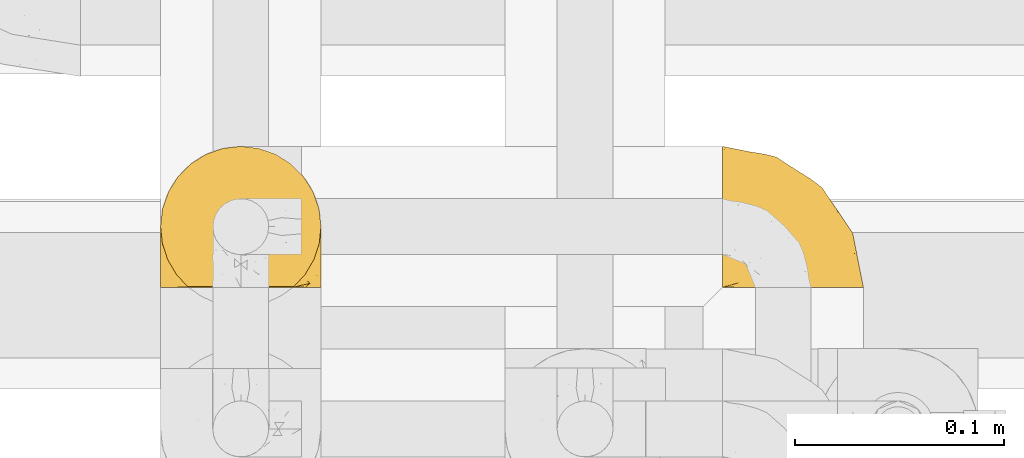
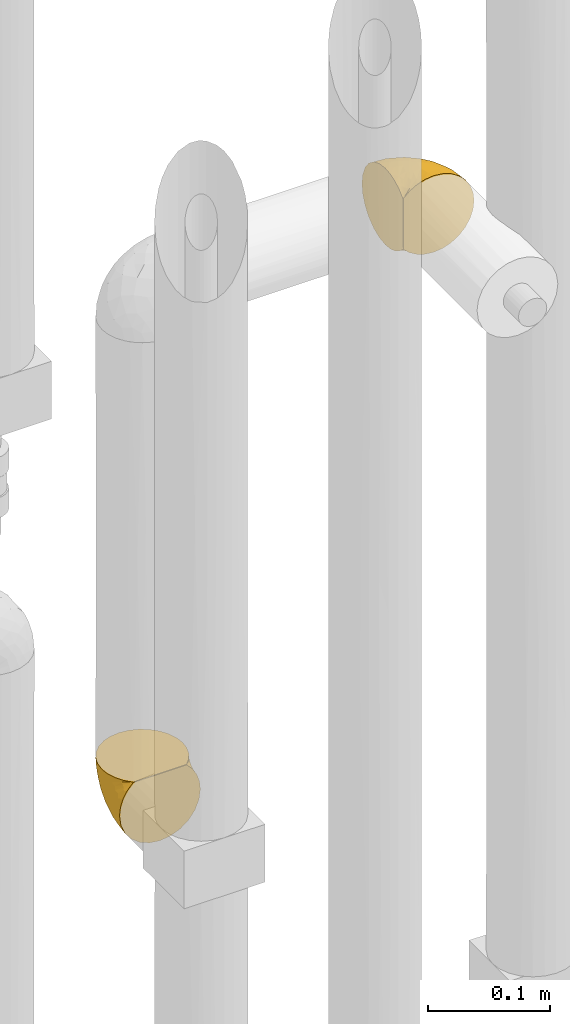
# One storey, part 284 of 827: 2 coverings.
"""IFC2X3 building model written with IfcOpenShell, lengths in millimetres."""

from ifc_helpers import new_model, entity, si_unit, converted_unit, derived_unit, direction, frame, origin, place, context, subcontext, project, spatial, faceted_brep, element, save


model = new_model("IFC2X3")

# Units and contexts
model_context = context("Model", 3, precision=0.01, world=origin(), true_north=direction((6.12303176911189e-17, 1.0)))
body_context = subcontext(model_context, "Body", "Model", "MODEL_VIEW")
ifc_project = project(units=[si_unit("LENGTHUNIT", "METRE", prefix="MILLI"), si_unit("AREAUNIT", "SQUARE_METRE"), si_unit("VOLUMEUNIT", "CUBIC_METRE"), converted_unit("PLANEANGLEUNIT", "DEGREE", entity("IfcRatioMeasure", 0.0174532925199433), si_unit("PLANEANGLEUNIT", "RADIAN"), dimensions=[0, 0, 0, 0, 0, 0, 0]), si_unit("MASSUNIT", "GRAM", prefix="KILO"), derived_unit("MASSDENSITYUNIT", [(si_unit("MASSUNIT", "GRAM", prefix="KILO"), 1), (si_unit("LENGTHUNIT", "METRE"), -3)]), derived_unit("MOMENTOFINERTIAUNIT", [(si_unit("LENGTHUNIT", "METRE"), 4)]), si_unit("TIMEUNIT", "SECOND"), si_unit("FREQUENCYUNIT", "HERTZ"), si_unit("THERMODYNAMICTEMPERATUREUNIT", "DEGREE_CELSIUS"), derived_unit("THERMALTRANSMITTANCEUNIT", [(si_unit("MASSUNIT", "GRAM", prefix="KILO"), 1), (si_unit("THERMODYNAMICTEMPERATUREUNIT", "KELVIN"), -1), (si_unit("TIMEUNIT", "SECOND"), -3)]), derived_unit("VOLUMETRICFLOWRATEUNIT", [(si_unit("LENGTHUNIT", "METRE"), 3), (si_unit("TIMEUNIT", "SECOND"), -1)]), derived_unit("MASSFLOWRATEUNIT", [(si_unit("MASSUNIT", "GRAM", prefix="KILO"), 1), (si_unit("TIMEUNIT", "SECOND"), -1)]), derived_unit("ROTATIONALFREQUENCYUNIT", [(si_unit("TIMEUNIT", "SECOND"), -1)]), si_unit("ELECTRICCURRENTUNIT", "AMPERE"), si_unit("ELECTRICVOLTAGEUNIT", "VOLT"), si_unit("POWERUNIT", "WATT"), si_unit("FORCEUNIT", "NEWTON", prefix="KILO"), si_unit("ILLUMINANCEUNIT", "LUX"), si_unit("LUMINOUSFLUXUNIT", "LUMEN"), si_unit("LUMINOUSINTENSITYUNIT", "CANDELA"), derived_unit("USERDEFINED", [(si_unit("MASSUNIT", "GRAM", prefix="KILO"), -1), (si_unit("LENGTHUNIT", "METRE"), -2), (si_unit("TIMEUNIT", "SECOND"), 3), (si_unit("LUMINOUSFLUXUNIT", "LUMEN"), 1)]), derived_unit("LINEARVELOCITYUNIT", [(si_unit("LENGTHUNIT", "METRE"), 1), (si_unit("TIMEUNIT", "SECOND"), -1)]), si_unit("PRESSUREUNIT", "PASCAL"), derived_unit("USERDEFINED", [(si_unit("LENGTHUNIT", "METRE"), -2), (si_unit("MASSUNIT", "GRAM", prefix="KILO"), 1), (si_unit("TIMEUNIT", "SECOND"), -2)]), derived_unit("LINEARFORCEUNIT", [(si_unit("MASSUNIT", "GRAM", prefix="KILO"), 1), (si_unit("LENGTHUNIT", "METRE"), 1), (si_unit("TIMEUNIT", "SECOND"), -2), (si_unit("LENGTHUNIT", "METRE"), -1)]), derived_unit("PLANARFORCEUNIT", [(si_unit("MASSUNIT", "GRAM", prefix="KILO"), 1), (si_unit("LENGTHUNIT", "METRE"), 1), (si_unit("TIMEUNIT", "SECOND"), -2), (si_unit("LENGTHUNIT", "METRE"), -2)])], contexts=[model_context])

# Site, building, storey
site_placement = place(None, origin())
site = spatial("IfcSite", under=ifc_project, at=site_placement, CompositionType="ELEMENT")
building_placement = place(site_placement, origin())
building = spatial("IfcBuilding", under=site, at=building_placement, CompositionType="ELEMENT")
storey_placement = place(building_placement, frame((0.0, 0.0, 28200.0)))
storey = spatial("IfcBuildingStorey", under=building, at=storey_placement, Name="08", CompositionType="ELEMENT", Elevation=28200.0)

# Coverings
covering_1_placement = place(storey_placement, frame((34787.8, 14991.21, 1669.95)))
element("IfcCovering", 1, at=covering_1_placement, inside=storey, Name=":ADSK_", ObjectType=":ADSK_", PredefinedType="INSULATION", context=body_context, shape_type="Brep", body=[
    faceted_brep([(74.68, 47.38, 69.15), (70.1, 54.67, 69.15), (64.01, 60.76, 69.15), (56.72, 65.34, 69.15), (48.6, 68.18, 69.15), (40.05, 69.15, 69.15), (31.49, 68.18, 69.15), (23.36, 65.33, 69.15), (16.07, 60.75, 69.15), (9.98, 54.66, 69.15), (5.4, 47.37, 69.15), (2.56, 39.25, 69.15), (1.6, 30.7, 69.15), (2.46, 22.59, 69.15), (5.01, 14.86, 69.15), (9.13, 7.84, 69.15), (14.62, 1.85, 69.15), (16.82, 1.85, 69.15), (18.56, 1.85, 69.15), (20.52, 1.85, 69.15), (22.49, 1.85, 69.15), (24.46, 1.85, 69.15), (26.42, 1.85, 69.15), (28.39, 1.85, 69.15), (30.36, 1.85, 69.15), (32.55, 1.85, 69.15), (34.75, 1.85, 69.15), (36.94, 1.85, 69.15), (39.13, 1.85, 69.15), (41.33, 1.85, 69.15), (43.52, 1.85, 69.15), (45.72, 1.85, 69.15), (47.91, 1.85, 69.15), (50.11, 1.85, 69.15), (52.3, 1.85, 69.15), (54.49, 1.85, 69.15), (56.69, 1.85, 69.15), (58.88, 1.85, 69.15), (61.08, 1.85, 69.15), (63.27, 1.85, 69.15), (65.47, 1.85, 69.15), (70.97, 7.85, 69.15), (75.09, 14.88, 69.15), (77.64, 22.61, 69.15), (78.5, 30.7, 69.15), (77.53, 39.26, 69.15), (14.62, 1.6, 68.89), (9.12, 1.6, 62.89), (5.0, 1.6, 55.87), (2.46, 1.6, 48.14), (1.6, 1.6, 40.05), (2.91, 1.6, 30.09), (6.75, 1.6, 20.82), (12.86, 1.6, 12.86), (20.82, 1.6, 6.75), (30.09, 1.6, 2.91), (40.05, 1.6, 1.6), (50.0, 1.6, 2.91), (59.27, 1.6, 6.75), (67.23, 1.6, 12.86), (73.34, 1.6, 20.82), (77.19, 1.6, 30.09), (78.5, 1.6, 40.05), (77.63, 1.6, 48.14), (75.09, 1.6, 55.87), (70.97, 1.6, 62.89), (65.47, 1.6, 68.89), (63.27, 1.6, 68.89), (62.29, 1.6, 68.89), (60.7, 1.6, 68.89), (59.11, 1.6, 68.89), (57.52, 1.6, 68.89), (55.93, 1.6, 68.89), (54.34, 1.6, 68.89), (52.76, 1.6, 68.89), (51.17, 1.6, 68.89), (49.58, 1.6, 68.89), (47.99, 1.6, 68.89), (46.4, 1.6, 68.89), (44.81, 1.6, 68.89), (43.22, 1.6, 68.89), (41.63, 1.6, 68.89), (40.05, 1.6, 68.89), (38.46, 1.6, 68.89), (36.87, 1.6, 68.89), (35.28, 1.6, 68.89), (33.69, 1.6, 68.89), (32.1, 1.6, 68.89), (30.51, 1.6, 68.89), (28.92, 1.6, 68.89), (27.33, 1.6, 68.89), (25.37, 1.6, 68.89), (23.4, 1.6, 68.89), (21.21, 1.6, 68.89), (19.01, 1.6, 68.89), (16.82, 1.6, 68.89), (42.32, 1.78, 68.97), (44.02, 1.77, 68.96), (47.13, 1.78, 68.97), (48.74, 1.77, 68.97), (23.57, 1.79, 68.98), (25.13, 1.78, 68.97), (61.34, 1.76, 68.96), (22.02, 1.77, 68.96), (29.72, 1.77, 68.96), (56.73, 1.76, 68.96), (55.14, 1.77, 68.96), (37.66, 1.77, 68.96), (64.12, 1.8, 69.0), (28.13, 1.76, 68.96), (26.62, 1.77, 68.96), (31.46, 1.78, 68.97), (16.16, 1.77, 68.96), (39.16, 1.77, 68.96), (50.37, 1.76, 68.96), (17.69, 1.77, 68.97), (19.17, 1.78, 68.97), (62.78, 1.77, 68.97), (58.35, 1.77, 68.96), (45.53, 1.77, 68.96), (59.91, 1.78, 68.97), (65.47, 1.77, 68.97), (65.47, 1.8, 69.02), (65.47, 1.82, 69.08), (14.62, 1.77, 68.97), (14.62, 1.72, 68.94), (14.62, 1.66, 68.92), (20.59, 1.76, 68.96), (32.99, 1.77, 68.96), (34.48, 1.76, 68.95), (51.91, 1.77, 68.96), (65.47, 1.66, 68.92), (65.47, 1.72, 68.94), (53.48, 1.78, 68.98), (14.62, 1.82, 69.08), (14.62, 1.8, 69.02), (40.77, 1.77, 68.96), (35.97, 1.78, 68.97), (7.84, 3.72, 61.33), (3.53, 7.41, 53.1), (8.32, 6.13, 63.33), (1.6, 21.47, 49.27), (2.19, 19.34, 55.53), (1.6, 26.8, 54.6), (1.6, 8.87, 41.99), (4.57, 9.2, 57.07), (3.96, 12.79, 57.95), (2.28, 14.62, 51.56), (7.69, 5.33, 61.7), (3.53, 17.64, 63.33), (8.32, 7.7, 65.0), (7.84, 9.41, 67.02), (1.6, 28.75, 61.87), (1.6, 16.15, 43.94), (4.34, 14.14, 61.21), (1.6, 29.16, 63.4), (4.52, 9.2, 26.0), (3.75, 42.07, 58.71), (2.45, 11.99, 33.48), (16.64, 24.62, 14.17), (9.54, 15.19, 18.43), (9.07, 28.65, 24.87), (13.94, 53.59, 45.01), (19.58, 58.06, 44.4), (16.37, 50.57, 35.53), (4.52, 18.36, 28.67), (7.49, 46.98, 49.25), (3.26, 36.04, 48.22), (7.49, 50.24, 59.72), (12.85, 56.1, 55.1), (32.9, 21.34, 5.25), (25.33, 18.4, 6.75), (16.64, 12.07, 10.47), (27.34, 64.92, 52.82), (26.2, 40.1, 16.81), (33.36, 44.08, 17.38), (31.42, 33.21, 10.56), (24.75, 29.63, 11.2), (40.05, 49.36, 21.38), (29.63, 57.02, 33.11), (40.05, 64.0, 43.3), (40.05, 56.68, 32.34), (2.35, 28.97, 44.72), (2.43, 19.16, 36.52), (22.66, 54.46, 34.15), (40.05, 66.44, 55.54), (19.58, 62.12, 57.42), (19.99, 45.49, 25.49), (28.21, 49.27, 23.96), (7.5, 37.37, 34.84), (4.04, 29.39, 36.87), (40.05, 15.2, 4.3), (16.14, 35.57, 20.65), (12.85, 41.7, 29.66), (10.47, 46.4, 39.6), (6.49, 41.41, 42.55), (40.05, 27.45, 6.74), (40.05, 38.4, 14.06), (47.37, 21.33, 5.28), (78.5, 29.16, 63.4), (76.34, 42.08, 58.71), (50.46, 57.04, 33.13), (52.91, 42.89, 18.52), (52.74, 64.92, 52.83), (60.5, 58.07, 44.4), (67.23, 51.29, 42.69), (67.23, 56.11, 55.1), (72.6, 46.99, 49.26), (70.55, 21.89, 20.72), (63.45, 16.62, 11.46), (62.61, 32.9, 17.69), (77.76, 15.6, 35.35), (78.5, 16.15, 43.94), (78.5, 8.87, 41.99), (71.93, 32.83, 29.34), (75.79, 20.56, 30.26), (53.16, 13.16, 4.93), (59.34, 49.91, 29.72), (70.55, 10.83, 17.46), (75.57, 12.99, 26.84), (72.6, 50.25, 59.73), (78.5, 28.75, 61.87), (78.5, 26.8, 54.6), (60.5, 62.13, 57.43), (76.82, 36.04, 48.2), (77.64, 28.1, 43.06), (78.5, 21.47, 49.27), (48.88, 33.8, 10.94), (54.76, 25.02, 8.92), (77.8, 8.45, 33.44), (67.23, 41.73, 29.67), (73.2, 39.27, 38.5), (77.86, 21.46, 39.06), (67.66, 33.56, 23.35), (75.99, 27.29, 34.97), (76.57, 7.41, 53.1), (73.21, 3.51, 59.68), (71.93, 4.68, 62.19), (71.07, 5.52, 64.11), (75.09, 8.75, 57.97), (76.13, 12.79, 57.95), (76.57, 17.65, 63.33), (77.69, 13.9, 51.77), (72.26, 9.42, 67.02), (71.77, 7.68, 64.98), (77.9, 19.33, 55.53), (75.75, 14.13, 61.22)], [[[0, 1, 2, 3, 4, 5, 6, 7, 8, 9, 10, 11, 12, 13, 14, 15, 16, 17, 18, 19, 20, 21, 22, 23, 24, 25, 26, 27, 28, 29, 30, 31, 32, 33, 34, 35, 36, 37, 38, 39, 40, 41, 42, 43, 44, 45]], [[46, 47, 48, 49, 50, 51, 52, 53, 54, 55, 56, 57, 58, 59, 60, 61, 62, 63, 64, 65, 66, 67, 68, 69, 70, 71, 72, 73, 74, 75, 76, 77, 78, 79, 80, 81, 82, 83, 84, 85, 86, 87, 88, 89, 90, 91, 92, 93, 94, 95]], [[96, 97, 30]], [[98, 77, 99]], [[100, 101, 21]], [[69, 68, 102]], [[20, 19, 103]], [[24, 23, 104]], [[20, 103, 100]], [[72, 105, 106]], [[84, 83, 107]], [[89, 88, 104]], [[108, 67, 66]], [[109, 110, 90]], [[111, 25, 24]], [[112, 17, 16]], [[82, 113, 83]], [[109, 23, 22]], [[114, 76, 75]], [[105, 36, 106]], [[104, 111, 24]], [[18, 115, 116]], [[97, 96, 80]], [[67, 108, 117]], [[105, 71, 118]], [[31, 97, 119]], [[102, 120, 69]], [[108, 121, 122, 123, 40]], [[112, 95, 115]], [[17, 115, 18]], [[94, 116, 115]], [[117, 68, 67]], [[38, 117, 39]], [[112, 124, 125, 126, 46]], [[17, 112, 115]], [[70, 120, 118]], [[39, 117, 108]], [[120, 38, 37]], [[120, 37, 118]], [[120, 70, 69]], [[116, 94, 127]], [[128, 86, 129]], [[117, 38, 102]], [[74, 130, 75]], [[99, 33, 32]], [[115, 95, 94]], [[39, 108, 40]], [[108, 66, 131, 132, 121]], [[105, 72, 71]], [[118, 37, 36]], [[71, 70, 118]], [[35, 106, 36]], [[36, 105, 118]], [[35, 133, 106]], [[74, 73, 133]], [[106, 133, 73]], [[99, 114, 33]], [[133, 35, 34]], [[73, 72, 106]], [[95, 112, 46]], [[112, 16, 134, 135, 124]], [[130, 114, 75]], [[99, 76, 114]], [[114, 130, 33]], [[34, 33, 130]], [[78, 77, 98]], [[98, 119, 78]], [[130, 133, 34]], [[133, 130, 74]], [[79, 97, 80]], [[98, 99, 32]], [[98, 32, 31]], [[77, 76, 99]], [[97, 79, 119]], [[136, 96, 29]], [[30, 97, 31]], [[136, 29, 28]], [[81, 80, 96]], [[29, 96, 30]], [[31, 119, 98]], [[119, 79, 78]], [[96, 136, 81]], [[82, 81, 136]], [[113, 107, 83]], [[84, 107, 137]], [[107, 27, 137]], [[113, 28, 107]], [[27, 107, 28]], [[85, 84, 137]], [[137, 27, 26]], [[113, 136, 28]], [[136, 113, 82]], [[109, 89, 104]], [[86, 85, 129]], [[89, 109, 90]], [[111, 87, 128]], [[26, 129, 137]], [[88, 111, 104]], [[25, 111, 128]], [[22, 110, 109]], [[23, 109, 104]], [[110, 91, 90]], [[100, 92, 101]], [[110, 22, 101]], [[91, 110, 101]], [[116, 19, 18]], [[111, 88, 87]], [[127, 103, 19]], [[25, 128, 26]], [[86, 128, 87]], [[128, 129, 26]], [[137, 129, 85]], [[120, 102, 38]], [[117, 102, 68]], [[91, 101, 92]], [[21, 101, 22]], [[93, 92, 103]], [[100, 21, 20]], [[100, 103, 92]], [[127, 93, 103]], [[93, 127, 94]], [[116, 127, 19]], [[126, 138, 47]], [[48, 138, 139]], [[140, 125, 124]], [[141, 142, 143]], [[144, 49, 139]], [[145, 140, 146]], [[48, 139, 49]], [[139, 145, 147]], [[144, 50, 49]], [[126, 125, 148]], [[14, 13, 149]], [[150, 146, 140]], [[148, 140, 145]], [[151, 150, 135]], [[151, 14, 149]], [[16, 15, 134]], [[13, 152, 149]], [[124, 150, 140]], [[141, 147, 142]], [[14, 151, 15]], [[15, 151, 134]], [[47, 46, 126]], [[139, 153, 144]], [[138, 48, 47]], [[125, 140, 148]], [[135, 134, 151]], [[146, 154, 142]], [[145, 146, 147]], [[148, 139, 138]], [[147, 141, 153]], [[147, 146, 142]], [[139, 147, 153]], [[139, 148, 145]], [[148, 138, 126]], [[154, 146, 150]], [[149, 143, 142]], [[151, 154, 150]], [[149, 142, 154]], [[13, 12, 155, 152]], [[152, 143, 149]], [[151, 149, 154]], [[150, 124, 135]], [[51, 156, 52]], [[155, 11, 157]], [[50, 144, 158]], [[159, 160, 161]], [[162, 163, 164]], [[158, 165, 156]], [[157, 166, 167]], [[166, 168, 169]], [[170, 55, 171]], [[161, 160, 165]], [[172, 54, 53]], [[160, 53, 52]], [[173, 7, 6]], [[54, 172, 171]], [[174, 175, 176]], [[170, 177, 176]], [[167, 143, 157]], [[178, 179, 180, 181]], [[157, 11, 10]], [[141, 182, 183]], [[160, 52, 156]], [[173, 179, 184]], [[8, 169, 9]], [[173, 6, 185]], [[155, 12, 11]], [[8, 7, 186]], [[162, 169, 163]], [[187, 184, 188]], [[180, 173, 185]], [[10, 168, 157]], [[54, 171, 55]], [[186, 173, 163]], [[157, 143, 152, 155]], [[189, 161, 190]], [[179, 173, 180]], [[9, 168, 10]], [[186, 169, 8]], [[187, 164, 184]], [[144, 183, 158]], [[172, 160, 159]], [[177, 174, 176]], [[55, 170, 191]], [[187, 192, 193]], [[183, 182, 190]], [[166, 194, 195]], [[167, 190, 182]], [[6, 5, 185]], [[173, 186, 7]], [[169, 186, 163]], [[169, 168, 9]], [[157, 168, 166]], [[190, 161, 165]], [[161, 193, 192]], [[183, 165, 158]], [[194, 189, 195]], [[191, 170, 196]], [[191, 56, 55]], [[175, 178, 197]], [[197, 196, 176]], [[170, 176, 196]], [[188, 175, 174]], [[197, 176, 175]], [[177, 170, 171]], [[171, 159, 177]], [[192, 177, 159]], [[187, 188, 174]], [[188, 179, 178]], [[174, 177, 192]], [[164, 187, 193]], [[174, 192, 187]], [[161, 192, 159]], [[194, 164, 193]], [[184, 164, 163]], [[189, 194, 193]], [[162, 166, 169]], [[161, 189, 193]], [[195, 190, 167]], [[173, 184, 163]], [[184, 179, 188]], [[164, 194, 162]], [[166, 162, 194]], [[190, 195, 189]], [[167, 182, 143]], [[167, 166, 195]], [[160, 172, 53]], [[171, 172, 159]], [[51, 50, 158]], [[160, 156, 165]], [[51, 158, 156]], [[183, 144, 153]], [[141, 183, 153]], [[190, 165, 183]], [[178, 175, 188]], [[143, 182, 141]], [[198, 191, 196]], [[45, 199, 200]], [[178, 201, 202]], [[201, 203, 204]], [[205, 206, 207]], [[57, 56, 191]], [[4, 185, 5]], [[208, 209, 210]], [[211, 212, 213]], [[208, 214, 215]], [[216, 209, 58]], [[201, 217, 202]], [[59, 218, 60]], [[60, 218, 219]], [[201, 178, 181, 180]], [[1, 0, 220]], [[201, 180, 203]], [[200, 199, 221, 222]], [[203, 185, 4]], [[3, 203, 4]], [[2, 1, 206]], [[217, 210, 202]], [[58, 209, 59]], [[3, 223, 203]], [[207, 220, 200]], [[204, 223, 206]], [[205, 204, 206]], [[207, 200, 224]], [[200, 222, 224]], [[206, 223, 2]], [[225, 222, 226]], [[220, 206, 1]], [[60, 219, 61]], [[57, 198, 216]], [[227, 202, 228]], [[3, 2, 223]], [[45, 44, 199]], [[0, 45, 200]], [[219, 211, 229]], [[230, 231, 214]], [[231, 207, 224]], [[210, 209, 228]], [[218, 209, 208]], [[226, 232, 225]], [[231, 230, 205]], [[202, 210, 228]], [[233, 230, 214]], [[227, 228, 198]], [[201, 204, 217]], [[211, 232, 212]], [[180, 185, 203]], [[61, 229, 62]], [[203, 223, 204]], [[200, 220, 0]], [[206, 220, 207]], [[225, 231, 224]], [[232, 226, 212]], [[214, 231, 234]], [[197, 227, 196]], [[191, 198, 57]], [[198, 228, 216]], [[202, 197, 178]], [[196, 227, 198]], [[197, 202, 227]], [[209, 216, 228]], [[58, 57, 216]], [[229, 211, 213]], [[215, 211, 219]], [[205, 217, 204]], [[210, 217, 230]], [[62, 229, 213]], [[219, 229, 61]], [[231, 205, 207]], [[217, 205, 230]], [[215, 214, 234]], [[233, 208, 210]], [[209, 218, 59]], [[219, 218, 208]], [[208, 215, 219]], [[232, 215, 234]], [[215, 232, 211]], [[232, 234, 225]], [[231, 225, 234]], [[222, 225, 224]], [[208, 233, 214]], [[210, 230, 233]], [[63, 213, 235]], [[213, 212, 235]], [[213, 63, 62]], [[236, 235, 237]], [[237, 132, 131]], [[235, 236, 64]], [[238, 239, 240]], [[63, 235, 64]], [[131, 66, 65]], [[236, 131, 65]], [[241, 221, 43]], [[236, 65, 64]], [[238, 121, 132]], [[42, 241, 43]], [[240, 239, 242]], [[41, 123, 243]], [[43, 221, 199, 44]], [[243, 122, 244]], [[226, 245, 242]], [[240, 242, 245]], [[121, 238, 244]], [[41, 40, 123]], [[132, 237, 238]], [[243, 42, 41]], [[131, 236, 237]], [[239, 238, 237]], [[244, 238, 240]], [[246, 240, 245]], [[246, 243, 244]], [[237, 235, 239]], [[242, 235, 212]], [[235, 242, 239]], [[222, 245, 226]], [[242, 212, 226]], [[222, 241, 245]], [[240, 246, 244]], [[245, 241, 246]], [[243, 246, 241]], [[241, 222, 221]], [[42, 243, 241]], [[122, 243, 123]], [[122, 121, 244]]]),
])
covering_2_placement = place(storey_placement, frame((35057.15, 14991.21, 2169.95)))
element("IfcCovering", 2, at=covering_2_placement, inside=storey, Name=":ADSK_", ObjectType=":ADSK_", PredefinedType="INSULATION", context=body_context, shape_type="Brep", body=[
    faceted_brep([(47.38, 1.6, 5.41), (54.67, 1.6, 9.99), (60.76, 1.6, 16.08), (65.34, 1.6, 23.37), (68.18, 1.6, 31.49), (69.15, 1.6, 40.05), (68.18, 1.6, 48.61), (65.33, 1.6, 56.73), (60.75, 1.6, 64.02), (54.66, 1.6, 70.11), (47.37, 1.6, 74.69), (39.25, 1.6, 77.53), (30.7, 1.6, 78.5), (22.59, 1.6, 77.63), (14.86, 1.6, 75.08), (7.84, 1.6, 70.97), (1.85, 1.6, 65.47), (1.85, 1.6, 63.27), (1.85, 1.6, 61.53), (1.85, 1.6, 59.57), (1.85, 1.6, 57.6), (1.85, 1.6, 55.63), (1.85, 1.6, 53.67), (1.85, 1.6, 51.7), (1.85, 1.6, 49.73), (1.85, 1.6, 47.54), (1.85, 1.6, 45.34), (1.85, 1.6, 43.15), (1.85, 1.6, 40.96), (1.85, 1.6, 38.76), (1.85, 1.6, 36.57), (1.85, 1.6, 34.37), (1.85, 1.6, 32.18), (1.85, 1.6, 29.98), (1.85, 1.6, 27.79), (1.85, 1.6, 25.6), (1.85, 1.6, 23.4), (1.85, 1.6, 21.21), (1.85, 1.6, 19.01), (1.85, 1.6, 16.82), (1.85, 1.6, 14.62), (7.85, 1.6, 9.12), (14.88, 1.6, 5.0), (22.61, 1.6, 2.46), (30.7, 1.6, 1.6), (39.26, 1.6, 2.56), (1.6, 1.85, 65.47), (1.6, 7.85, 70.97), (1.6, 14.87, 75.09), (1.6, 22.6, 77.63), (1.6, 30.7, 78.5), (1.6, 40.65, 77.19), (1.6, 49.92, 73.34), (1.6, 57.88, 67.23), (1.6, 63.99, 59.27), (1.6, 67.84, 50.0), (1.6, 69.15, 40.05), (1.6, 67.84, 30.09), (1.6, 63.99, 20.82), (1.6, 57.88, 12.86), (1.6, 49.92, 6.75), (1.6, 40.65, 2.91), (1.6, 30.7, 1.6), (1.6, 22.6, 2.46), (1.6, 14.87, 5.0), (1.6, 7.85, 9.12), (1.6, 1.85, 14.62), (1.6, 1.85, 16.82), (1.6, 1.85, 17.8), (1.6, 1.85, 19.39), (1.6, 1.85, 20.98), (1.6, 1.85, 22.57), (1.6, 1.85, 24.16), (1.6, 1.85, 25.75), (1.6, 1.85, 27.33), (1.6, 1.85, 28.92), (1.6, 1.85, 30.51), (1.6, 1.85, 32.1), (1.6, 1.85, 33.69), (1.6, 1.85, 35.28), (1.6, 1.85, 36.87), (1.6, 1.85, 38.46), (1.6, 1.85, 40.05), (1.6, 1.85, 41.63), (1.6, 1.85, 43.22), (1.6, 1.85, 44.81), (1.6, 1.85, 46.4), (1.6, 1.85, 47.99), (1.6, 1.85, 49.58), (1.6, 1.85, 51.17), (1.6, 1.85, 52.76), (1.6, 1.85, 54.72), (1.6, 1.85, 56.69), (1.6, 1.85, 58.88), (1.6, 1.85, 61.08), (1.6, 1.85, 63.27), (1.78, 1.77, 37.77), (1.77, 1.78, 36.07), (1.78, 1.77, 32.96), (1.77, 1.77, 31.36), (1.79, 1.76, 56.52), (1.78, 1.77, 54.96), (1.76, 1.79, 18.75), (1.77, 1.78, 58.07), (1.77, 1.78, 50.37), (1.76, 1.78, 23.36), (1.77, 1.78, 24.95), (1.77, 1.78, 42.43), (1.8, 1.74, 15.97), (1.76, 1.78, 51.96), (1.77, 1.78, 53.47), (1.78, 1.77, 48.63), (1.77, 1.78, 63.93), (1.77, 1.78, 40.93), (1.76, 1.78, 29.72), (1.77, 1.77, 62.4), (1.78, 1.77, 60.92), (1.77, 1.77, 17.31), (1.77, 1.78, 21.74), (1.77, 1.78, 34.56), (1.78, 1.77, 20.18), (1.77, 1.77, 14.62), (1.8, 1.72, 14.62), (1.82, 1.66, 14.62), (1.77, 1.77, 65.47), (1.72, 1.8, 65.47), (1.66, 1.82, 65.47), (1.76, 1.79, 59.5), (1.77, 1.78, 47.1), (1.76, 1.79, 45.61), (1.77, 1.78, 28.18), (1.66, 1.82, 14.62), (1.72, 1.8, 14.62), (1.78, 1.76, 26.61), (1.82, 1.66, 65.47), (1.8, 1.72, 65.47), (1.77, 1.78, 39.32), (1.78, 1.77, 44.12), (3.72, 9.41, 72.26), (7.41, 17.65, 76.57), (6.13, 7.41, 71.77), (19.34, 15.21, 77.9), (17.64, 7.41, 76.56), (26.8, 16.15, 78.5), (8.87, 28.75, 78.5), (9.2, 13.67, 75.52), (12.79, 12.79, 76.13), (14.62, 19.18, 77.81), (5.33, 9.04, 72.4), (7.7, 5.74, 71.77), (9.41, 3.72, 72.25), (28.75, 8.87, 78.5), (21.47, 21.47, 78.5), (16.15, 26.8, 78.5), (14.14, 9.53, 75.75), (29.16, 7.34, 78.5), (9.2, 44.74, 75.57), (42.07, 12.03, 76.34), (11.99, 37.26, 77.64), (24.62, 56.57, 63.45), (15.19, 52.31, 70.55), (28.65, 45.87, 71.02), (53.59, 25.73, 66.15), (58.06, 26.34, 60.51), (50.57, 35.21, 63.72), (18.36, 42.07, 75.57), (46.98, 21.49, 72.61), (36.04, 22.52, 76.83), (50.24, 11.02, 72.61), (56.1, 15.64, 67.24), (21.34, 65.49, 47.19), (18.4, 63.99, 54.76), (12.07, 60.27, 63.45), (64.92, 17.92, 52.75), (40.1, 53.93, 53.89), (44.08, 53.36, 46.73), (33.21, 60.18, 48.67), (29.63, 59.54, 55.34), (49.36, 49.36, 40.05), (57.02, 37.63, 50.46), (64.0, 27.45, 40.05), (56.68, 38.4, 40.05), (28.97, 26.02, 77.74), (19.16, 34.22, 77.66), (54.46, 36.59, 57.43), (66.44, 15.2, 40.05), (62.12, 13.32, 60.51), (45.49, 45.25, 60.1), (49.27, 46.78, 51.88), (37.37, 35.9, 72.59), (29.39, 33.87, 76.05), (15.2, 66.44, 40.05), (35.57, 50.09, 63.95), (41.7, 41.08, 67.24), (46.4, 31.14, 69.62), (41.41, 28.19, 73.6), (27.45, 64.0, 40.05), (38.4, 56.68, 40.05), (21.33, 65.46, 32.72), (29.16, 7.34, 1.6), (42.08, 12.03, 3.75), (57.04, 37.61, 29.63), (42.89, 52.22, 27.18), (64.92, 17.91, 27.35), (58.07, 26.34, 19.59), (51.29, 28.05, 12.86), (56.11, 15.64, 12.86), (46.99, 21.48, 7.49), (21.89, 50.02, 9.54), (16.62, 59.28, 16.64), (32.9, 53.05, 17.48), (15.6, 35.39, 2.33), (16.15, 26.8, 1.6), (8.87, 28.75, 1.6), (32.83, 41.4, 8.17), (20.56, 40.48, 4.3), (13.16, 65.81, 26.94), (49.91, 41.02, 20.75), (10.83, 53.28, 9.54), (12.99, 43.9, 4.52), (50.25, 11.01, 7.49), (28.75, 8.87, 1.6), (26.8, 16.15, 1.6), (62.13, 13.31, 19.59), (36.04, 22.54, 3.27), (28.1, 27.68, 2.45), (21.47, 21.47, 1.6), (33.8, 59.8, 31.21), (25.02, 61.82, 25.33), (8.45, 37.3, 2.29), (41.73, 41.07, 12.86), (39.27, 32.24, 6.89), (21.46, 31.68, 2.23), (33.56, 47.4, 12.43), (27.29, 35.77, 4.1), (7.41, 17.65, 3.53), (3.51, 11.06, 6.88), (4.68, 8.55, 8.16), (5.52, 6.63, 9.02), (8.75, 12.77, 5.0), (12.79, 12.79, 3.96), (17.65, 7.41, 3.52), (13.9, 18.97, 2.4), (9.42, 3.72, 7.83), (7.68, 5.76, 8.32), (19.33, 15.21, 2.19), (14.13, 9.52, 4.34)], [[[0, 1, 2, 3, 4, 5, 6, 7, 8, 9, 10, 11, 12, 13, 14, 15, 16, 17, 18, 19, 20, 21, 22, 23, 24, 25, 26, 27, 28, 29, 30, 31, 32, 33, 34, 35, 36, 37, 38, 39, 40, 41, 42, 43, 44, 45]], [[46, 47, 48, 49, 50, 51, 52, 53, 54, 55, 56, 57, 58, 59, 60, 61, 62, 63, 64, 65, 66, 67, 68, 69, 70, 71, 72, 73, 74, 75, 76, 77, 78, 79, 80, 81, 82, 83, 84, 85, 86, 87, 88, 89, 90, 91, 92, 93, 94, 95]], [[96, 97, 30]], [[98, 77, 99]], [[100, 101, 21]], [[69, 68, 102]], [[20, 19, 103]], [[24, 23, 104]], [[20, 103, 100]], [[72, 105, 106]], [[84, 83, 107]], [[89, 88, 104]], [[108, 67, 66]], [[109, 110, 90]], [[111, 25, 24]], [[112, 17, 16]], [[82, 113, 83]], [[109, 23, 22]], [[114, 76, 75]], [[105, 36, 106]], [[104, 111, 24]], [[18, 115, 116]], [[97, 96, 80]], [[67, 108, 117]], [[105, 71, 118]], [[31, 97, 119]], [[102, 120, 69]], [[108, 121, 122, 123, 40]], [[112, 95, 115]], [[17, 115, 18]], [[94, 116, 115]], [[117, 68, 67]], [[38, 117, 39]], [[112, 124, 125, 126, 46]], [[17, 112, 115]], [[70, 120, 118]], [[39, 117, 108]], [[120, 38, 37]], [[120, 37, 118]], [[120, 70, 69]], [[116, 94, 127]], [[128, 86, 129]], [[117, 38, 102]], [[74, 130, 75]], [[99, 33, 32]], [[115, 95, 94]], [[39, 108, 40]], [[108, 66, 131, 132, 121]], [[105, 72, 71]], [[118, 37, 36]], [[71, 70, 118]], [[35, 106, 36]], [[36, 105, 118]], [[35, 133, 106]], [[74, 73, 133]], [[106, 133, 73]], [[99, 114, 33]], [[133, 35, 34]], [[73, 72, 106]], [[95, 112, 46]], [[112, 16, 134, 135, 124]], [[130, 114, 75]], [[99, 76, 114]], [[114, 130, 33]], [[34, 33, 130]], [[78, 77, 98]], [[98, 119, 78]], [[130, 133, 34]], [[133, 130, 74]], [[79, 97, 80]], [[98, 99, 32]], [[98, 32, 31]], [[77, 76, 99]], [[97, 79, 119]], [[136, 96, 29]], [[30, 97, 31]], [[136, 29, 28]], [[81, 80, 96]], [[29, 96, 30]], [[31, 119, 98]], [[119, 79, 78]], [[96, 136, 81]], [[82, 81, 136]], [[113, 107, 83]], [[84, 107, 137]], [[107, 27, 137]], [[113, 28, 107]], [[27, 107, 28]], [[85, 84, 137]], [[137, 27, 26]], [[113, 136, 28]], [[136, 113, 82]], [[109, 89, 104]], [[86, 85, 129]], [[89, 109, 90]], [[111, 87, 128]], [[26, 129, 137]], [[88, 111, 104]], [[25, 111, 128]], [[22, 110, 109]], [[23, 109, 104]], [[110, 91, 90]], [[100, 92, 101]], [[110, 22, 101]], [[91, 110, 101]], [[116, 19, 18]], [[111, 88, 87]], [[127, 103, 19]], [[25, 128, 26]], [[86, 128, 87]], [[128, 129, 26]], [[137, 129, 85]], [[120, 102, 38]], [[117, 102, 68]], [[91, 101, 92]], [[21, 101, 22]], [[93, 92, 103]], [[100, 21, 20]], [[100, 103, 92]], [[127, 93, 103]], [[93, 127, 94]], [[116, 127, 19]], [[126, 138, 47]], [[48, 138, 139]], [[140, 125, 124]], [[141, 142, 143]], [[144, 49, 139]], [[145, 140, 146]], [[48, 139, 49]], [[139, 145, 147]], [[144, 50, 49]], [[126, 125, 148]], [[14, 13, 142]], [[149, 146, 140]], [[148, 140, 145]], [[150, 149, 135]], [[150, 14, 142]], [[16, 15, 134]], [[13, 151, 142]], [[124, 149, 140]], [[141, 143, 152]], [[14, 150, 15]], [[15, 150, 134]], [[47, 46, 126]], [[139, 153, 144]], [[138, 48, 47]], [[125, 140, 148]], [[135, 134, 150]], [[146, 154, 141]], [[145, 146, 147]], [[148, 139, 138]], [[147, 152, 153]], [[147, 146, 141]], [[139, 147, 153]], [[139, 148, 145]], [[148, 138, 126]], [[147, 141, 152]], [[146, 149, 154]], [[150, 154, 149]], [[142, 141, 154]], [[13, 12, 155, 151]], [[151, 143, 142]], [[150, 142, 154]], [[149, 124, 135]], [[51, 156, 52]], [[155, 11, 157]], [[50, 144, 158]], [[159, 160, 161]], [[162, 163, 164]], [[158, 165, 156]], [[157, 166, 167]], [[166, 168, 169]], [[170, 55, 171]], [[161, 160, 165]], [[172, 54, 53]], [[160, 53, 52]], [[173, 7, 6]], [[54, 172, 171]], [[174, 175, 176]], [[170, 177, 176]], [[167, 143, 157]], [[178, 179, 180, 181]], [[157, 11, 10]], [[152, 182, 183]], [[160, 52, 156]], [[173, 179, 184]], [[8, 169, 9]], [[173, 6, 185]], [[155, 12, 11]], [[8, 7, 186]], [[162, 169, 163]], [[187, 184, 188]], [[180, 173, 185]], [[10, 168, 157]], [[54, 171, 55]], [[186, 173, 163]], [[157, 143, 151, 155]], [[189, 161, 190]], [[179, 173, 180]], [[9, 168, 10]], [[186, 169, 8]], [[187, 164, 184]], [[144, 183, 158]], [[172, 160, 159]], [[177, 174, 176]], [[55, 170, 191]], [[187, 192, 193]], [[183, 182, 190]], [[166, 194, 195]], [[167, 190, 182]], [[6, 5, 185]], [[173, 186, 7]], [[169, 186, 163]], [[169, 168, 9]], [[157, 168, 166]], [[190, 161, 165]], [[161, 193, 192]], [[183, 165, 158]], [[194, 189, 195]], [[191, 170, 196]], [[191, 56, 55]], [[175, 178, 197]], [[197, 196, 176]], [[170, 176, 196]], [[188, 175, 174]], [[197, 176, 175]], [[177, 170, 171]], [[171, 159, 177]], [[192, 177, 159]], [[187, 188, 174]], [[188, 179, 178]], [[174, 177, 192]], [[164, 187, 193]], [[174, 192, 187]], [[161, 192, 159]], [[194, 164, 193]], [[184, 164, 163]], [[189, 194, 193]], [[162, 166, 169]], [[161, 189, 193]], [[195, 190, 167]], [[173, 184, 163]], [[184, 179, 188]], [[164, 194, 162]], [[166, 162, 194]], [[190, 195, 189]], [[167, 182, 143]], [[167, 166, 195]], [[160, 172, 53]], [[171, 172, 159]], [[51, 50, 158]], [[160, 156, 165]], [[51, 158, 156]], [[183, 144, 153]], [[152, 183, 153]], [[190, 165, 183]], [[178, 175, 188]], [[143, 182, 152]], [[198, 191, 196]], [[45, 199, 200]], [[178, 201, 202]], [[201, 203, 204]], [[205, 206, 207]], [[57, 56, 191]], [[4, 185, 5]], [[208, 209, 210]], [[211, 212, 213]], [[208, 214, 215]], [[216, 209, 58]], [[201, 217, 202]], [[59, 218, 60]], [[60, 218, 219]], [[201, 178, 181, 180]], [[1, 0, 220]], [[201, 180, 203]], [[200, 199, 221, 222]], [[203, 185, 4]], [[3, 203, 4]], [[2, 1, 206]], [[217, 210, 202]], [[58, 209, 59]], [[3, 223, 203]], [[207, 220, 200]], [[204, 223, 206]], [[205, 204, 206]], [[207, 200, 224]], [[200, 222, 224]], [[206, 223, 2]], [[225, 222, 226]], [[220, 206, 1]], [[60, 219, 61]], [[57, 198, 216]], [[227, 202, 228]], [[3, 2, 223]], [[45, 44, 199]], [[0, 45, 200]], [[219, 211, 229]], [[230, 231, 214]], [[231, 207, 224]], [[210, 209, 228]], [[218, 209, 208]], [[226, 232, 225]], [[231, 230, 205]], [[202, 210, 228]], [[233, 230, 214]], [[227, 228, 198]], [[201, 204, 217]], [[211, 232, 212]], [[180, 185, 203]], [[61, 229, 62]], [[203, 223, 204]], [[200, 220, 0]], [[206, 220, 207]], [[225, 231, 224]], [[232, 226, 212]], [[214, 231, 234]], [[197, 227, 196]], [[191, 198, 57]], [[198, 228, 216]], [[202, 197, 178]], [[196, 227, 198]], [[197, 202, 227]], [[209, 216, 228]], [[58, 57, 216]], [[229, 211, 213]], [[215, 211, 219]], [[205, 217, 204]], [[210, 217, 230]], [[62, 229, 213]], [[219, 229, 61]], [[231, 205, 207]], [[217, 205, 230]], [[215, 214, 234]], [[233, 208, 210]], [[209, 218, 59]], [[219, 218, 208]], [[208, 215, 219]], [[232, 215, 234]], [[215, 232, 211]], [[232, 234, 225]], [[231, 225, 234]], [[222, 225, 224]], [[208, 233, 214]], [[210, 230, 233]], [[63, 213, 235]], [[213, 212, 235]], [[213, 63, 62]], [[236, 235, 237]], [[237, 132, 131]], [[235, 236, 64]], [[238, 239, 240]], [[63, 235, 64]], [[131, 66, 65]], [[236, 131, 65]], [[241, 221, 43]], [[236, 65, 64]], [[238, 121, 132]], [[42, 241, 43]], [[240, 239, 242]], [[41, 123, 243]], [[43, 221, 199, 44]], [[243, 122, 244]], [[226, 245, 242]], [[240, 242, 245]], [[121, 238, 244]], [[41, 40, 123]], [[132, 237, 238]], [[243, 42, 41]], [[131, 236, 237]], [[239, 238, 237]], [[244, 238, 240]], [[246, 240, 245]], [[246, 243, 244]], [[237, 235, 239]], [[242, 235, 212]], [[235, 242, 239]], [[222, 245, 226]], [[242, 212, 226]], [[222, 241, 245]], [[240, 246, 244]], [[245, 241, 246]], [[243, 246, 241]], [[241, 222, 221]], [[42, 243, 241]], [[122, 243, 123]], [[122, 121, 244]]]),
])

save(model, "model.ifc")
